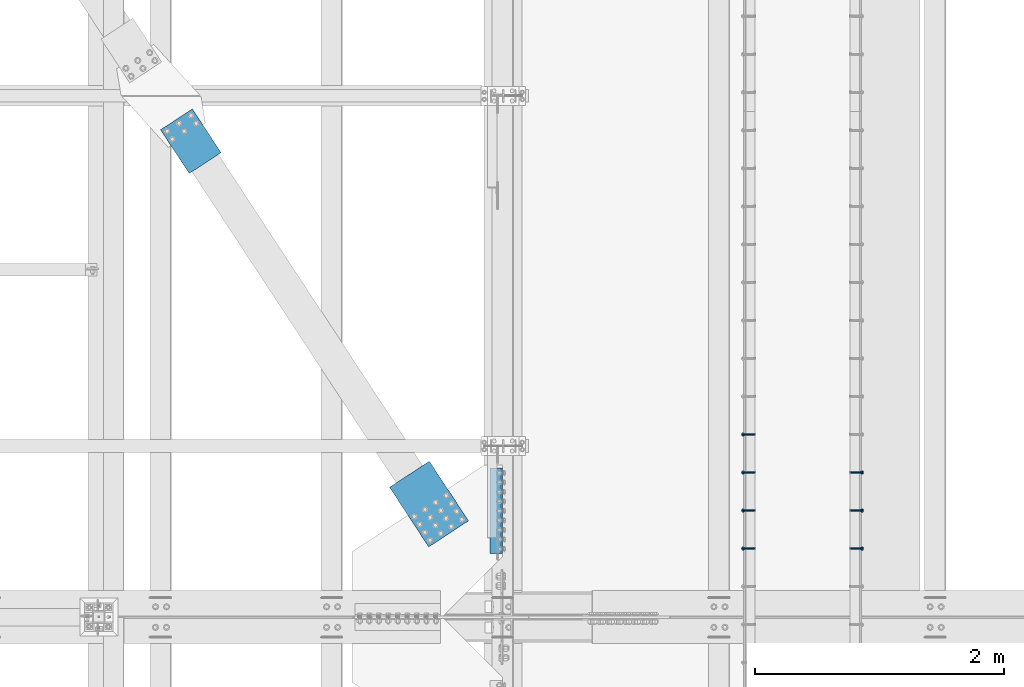
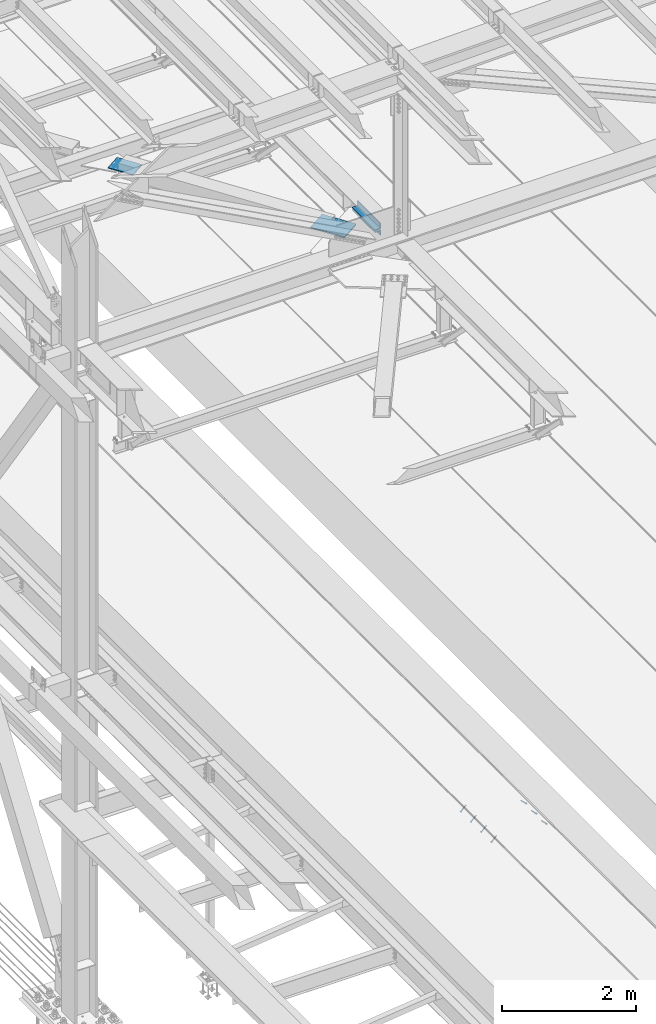
# One storey, part 2377 of 3843: 7 members, 4 beams, 4 elements without a shape of their own.
"""IFC2X3 building model written with IfcOpenShell, lengths in millimetres."""

import ifcopenshell
import ifcopenshell.guid

model = None  # the IFC model being written
_history = None  # IfcOwnerHistory: only IFC2X3 demands one
_inside = {}  # id of a spatial element -> (the spatial element, [elements in it])
_under = {}  # id of a project, library or spatial element -> (it, [spatial elements below it])
_declared = {}  # id of a project -> (the project, [libraries it declares])
_typed = {}  # id of a type object -> (the type object, [elements of that type])
_made_of = {}  # id of a material, layer set ... -> (it, [elements and type objects made of it])


def new_model(schema):
    """Start an empty IFC model of exactly this schema.

    Asked for "IFC4X3", IfcOpenShell would pick the latest addendum, in which some entities
    have other attributes; the version numbers below select the first issue.
    IFC2X3 requires an IfcOwnerHistory on every rooted entity: one is made here for all.
    """
    global model, _history
    if schema == "IFC4X3":
        model = ifcopenshell.file(schema_version=(4, 3, 0, 0))
    else:
        model = ifcopenshell.file(schema=schema)
    _inside.clear()
    _under.clear()
    _declared.clear()
    _typed.clear()
    _made_of.clear()
    _history = None
    if model.schema == "IFC2X3":
        org = make("IfcOrganization", Name="unknown")
        user = make(
            "IfcPersonAndOrganization",
            ThePerson=make("IfcPerson", FamilyName="unknown"),
            TheOrganization=org,
        )
        app = make(
            "IfcApplication",
            ApplicationDeveloper=org,
            Version="unknown",
            ApplicationFullName="unknown",
            ApplicationIdentifier="unknown",
        )
        _history = make(
            "IfcOwnerHistory",
            OwningUser=user,
            OwningApplication=app,
            ChangeAction="ADDED",
            CreationDate=0,
        )
    return model


def make(cls, **values):
    """One entity of the class cls with the attributes given. An attribute that is None is left unset."""
    return model.create_entity(
        cls, **{name: value for name, value in values.items() if value is not None}
    )


def rooted(cls, **values):
    """An entity with a GlobalId (a new one), such as an element, a storey or a relation."""
    return make(cls, GlobalId=ifcopenshell.guid.new(), OwnerHistory=_history, **values)


def si_unit(unit_type, name, prefix=None):
    """IfcSIUnit, for example si_unit("LENGTHUNIT", "METRE", prefix="MILLI")."""
    return make("IfcSIUnit", UnitType=unit_type, Prefix=prefix, Name=name)


def assignment(units):
    """IfcUnitAssignment: the units of a project."""
    return None if units is None else make("IfcUnitAssignment", Units=units)


def point(xyz):
    """IfcCartesianPoint."""
    return None if xyz is None else make("IfcCartesianPoint", Coordinates=xyz)


def direction(xyz):
    """IfcDirection."""
    return None if xyz is None else make("IfcDirection", DirectionRatios=xyz)


def frame(location, z_axis=None, x_axis=None):
    """IfcAxis2Placement3D, a coordinate frame: its origin and axes. An axis left out is left unset."""
    return make(
        "IfcAxis2Placement3D",
        Location=point(location),
        Axis=direction(z_axis),
        RefDirection=direction(x_axis),
    )


def origin_with_axes():
    """The frame at (0, 0, 0) with the z axis (0, 0, 1) and the x axis (1, 0, 0) written out."""
    return frame((0.0, 0.0, 0.0), z_axis=(0.0, 0.0, 1.0), x_axis=(1.0, 0.0, 0.0))


def place(relative_to, where):
    """IfcLocalPlacement: puts the frame where relative to a parent placement (None: the world)."""
    return make(
        "IfcLocalPlacement", PlacementRelTo=relative_to, RelativePlacement=where
    )


def context(
    kind, dimensions, precision=None, world=None, true_north=None, identifier=None
):
    """IfcGeometricRepresentationContext, for example the 3D "Model" context."""
    return make(
        "IfcGeometricRepresentationContext",
        ContextIdentifier=identifier,
        ContextType=kind,
        CoordinateSpaceDimension=dimensions,
        Precision=precision,
        WorldCoordinateSystem=world,
        TrueNorth=true_north,
    )


def subcontext(parent, identifier, kind, view, scale=None):
    """IfcGeometricRepresentationSubContext, for example "Body" below "Model"."""
    return make(
        "IfcGeometricRepresentationSubContext",
        ContextIdentifier=identifier,
        ContextType=kind,
        ParentContext=parent,
        TargetScale=scale,
        TargetView=view,
    )


def project(units=None, contexts=None):
    """IfcProject with its units and contexts."""
    return rooted(
        "IfcProject",
        Name="project",
        RepresentationContexts=contexts,
        UnitsInContext=assignment(units),
    )


def spatial(cls, under=None, at=None, **own):
    """A site, building, storey or space (cls), placed at a placement, below another one or the project."""
    s = rooted(cls, ObjectPlacement=at, **own)
    if under is not None:
        _under.setdefault(under.id(), (under, []))[1].append(s)
    return s


def faces_of(points, faces, orient=None, outer=None):
    """IfcFace entities. A face is a list of loops; a loop is a list of indices into points, from 0.

    orient and outer hold one flag for each loop. By default every Orientation is true, the
    first loop of a face is its IfcFaceOuterBound and the others are IfcFaceBound.
    """
    made = []
    for i, loops in enumerate(faces):
        bounds = []
        for j, loop in enumerate(loops):
            is_outer = j == 0 if outer is None else outer[i][j]
            bounds.append(
                make(
                    "IfcFaceOuterBound" if is_outer else "IfcFaceBound",
                    Bound=make("IfcPolyLoop", Polygon=[points[k] for k in loop]),
                    Orientation=True if orient is None else orient[i][j],
                )
            )
        made.append(make("IfcFace", Bounds=bounds))
    return made


def faceted_brep(points, faces, orient=None, outer=None, voids=None):
    """IfcFacetedBrep: a solid bounded by flat faces; with voids (closed shells), ...WithVoids."""
    shared = [point(p) for p in points]
    hull = make("IfcClosedShell", CfsFaces=faces_of(shared, faces, orient, outer))
    if voids is None:
        return make("IfcFacetedBrep", Outer=hull)
    return make(
        "IfcFacetedBrepWithVoids",
        Outer=hull,
        Voids=[
            make(cls, CfsFaces=faces_of(shared, fs, o, b)) for cls, fs, o, b in voids
        ],
    )


def shape(context_of_items, identifier, shape_type, items):
    """IfcShapeRepresentation: the items that make up one representation, for example the "Body"."""
    return make(
        "IfcShapeRepresentation",
        ContextOfItems=context_of_items,
        RepresentationIdentifier=identifier,
        RepresentationType=shape_type,
        Items=items,
    )


def material(Name=None, Category=None):
    """IfcMaterial."""
    return make("IfcMaterial", Name=Name, Category=Category)


def made_of(thing, what):
    """Note that an element or type object is made of a material, layer set ...; save() writes the relation."""
    if what is not None:
        _made_of.setdefault(what.id(), (what, []))[1].append(thing)
    return thing


def type_object(cls, material=None, **own):
    """A type object (cls), such as IfcWallType, which elements share."""
    return made_of(rooted(cls, **own), material)


def element(
    cls,
    number,
    at=None,
    inside=None,
    cuts=None,
    type_object=None,
    material=None,
    context=None,
    identifier="Body",
    shape_type=None,
    held_by="IfcProductDefinitionShape",
    body=None,
    shapes=None,
    **own,
):
    """One element of the class cls, such as IfcWall. Its Tag is "e" and its number.

    at: its placement. inside: the storey or other place that contains it. cuts: it is an
    opening in that element (IfcRelVoidsElement). A single representation is given by context,
    identifier, shape_type and body (its items); several are given by shapes. held_by: the class
    of the entity that holds the representations. save() writes the other relations.
    """
    e = rooted(cls, Tag="e%d" % number, ObjectPlacement=at, **own)
    if body is not None:
        shapes = [shape(context, identifier, shape_type, body)]
    if shapes is not None:
        e.Representation = make(held_by, Representations=shapes)
    if inside is not None:
        _inside.setdefault(inside.id(), (inside, []))[1].append(e)
    if cuts is not None:
        rooted(
            "IfcRelVoidsElement", RelatingBuildingElement=cuts, RelatedOpeningElement=e
        )
    if type_object is not None:
        _typed.setdefault(type_object.id(), (type_object, []))[1].append(e)
    return made_of(e, material)


def aggregate(whole, parts):
    """IfcRelAggregates: a whole, such as a stair, and the parts it consists of."""
    return rooted("IfcRelAggregates", RelatingObject=whole, RelatedObjects=parts)


def save(model, path):
    """Write the relations noted so far, then the file.

    IfcRelAggregates (storeys below a building ...), IfcRelContainedInSpatialStructure (elements
    in a storey), IfcRelDefinesByType, IfcRelAssociatesMaterial and IfcRelDeclares: one each for
    every whole, place, type object, material and project.
    """
    for whole, parts in _under.values():
        aggregate(whole, parts)
    for where, things in _inside.values():
        rooted(
            "IfcRelContainedInSpatialStructure",
            RelatedElements=things,
            RelatingStructure=where,
        )
    for kind, things in _typed.values():
        rooted("IfcRelDefinesByType", RelatedObjects=things, RelatingType=kind)
    for what, things in _made_of.values():
        rooted("IfcRelAssociatesMaterial", RelatedObjects=things, RelatingMaterial=what)
    for by, libraries in _declared.values():
        rooted("IfcRelDeclares", RelatingContext=by, RelatedDefinitions=libraries)
    model.write(path)


model = new_model("IFC2X3")

# Units and contexts
model_context = context("Model", 3, precision=1e-05, world=origin_with_axes())
body_context = subcontext(model_context, "Body", "Model", "MODEL_VIEW")
ifc_project = project(units=[si_unit("LENGTHUNIT", "METRE", prefix="MILLI"), si_unit("AREAUNIT", "SQUARE_METRE"), si_unit("VOLUMEUNIT", "CUBIC_METRE"), si_unit("MASSUNIT", "GRAM", prefix="KILO"), si_unit("TIMEUNIT", "SECOND"), si_unit("PLANEANGLEUNIT", "RADIAN"), si_unit("SOLIDANGLEUNIT", "STERADIAN"), si_unit("THERMODYNAMICTEMPERATUREUNIT", "DEGREE_CELSIUS"), si_unit("LUMINOUSINTENSITYUNIT", "LUMEN")], contexts=[model_context])

# Site, building, storey
site_placement = place(None, origin_with_axes())
site = spatial("IfcSite", under=ifc_project, at=site_placement, CompositionType="ELEMENT")
building_placement = place(site_placement, origin_with_axes())
building = spatial("IfcBuilding", under=site, at=building_placement, Name="Undefined", CompositionType="ELEMENT")
storey_placement = place(building_placement, origin_with_axes())
storey = spatial("IfcBuildingStorey", under=building, at=storey_placement, Name="Undefined", CompositionType="ELEMENT", Elevation=0.0)

# Assembly, members
assembly_1_placement = place(storey_placement, origin_with_axes())
assembly_1 = element("IfcElementAssembly", 1, at=assembly_1_placement, inside=storey, Name="EMBED_ANGLE", AssemblyPlace="NOTDEFINED", PredefinedType="RIGID_FRAME")
ifc_material_1 = material(Name="STEEL/A108")
member_type = type_object("IfcMemberType", PredefinedType="NOTDEFINED")
member_1_placement = place(assembly_1_placement, frame((44851.3834999999, 67821.175189209, 30456.1875), z_axis=(0.0, 1.0, 0.0), x_axis=(0.707106781186548, 0.0, -0.707106781186548)))
member_1 = element("IfcMember", 2, at=member_1_placement, type_object=member_type, material=ifc_material_1, Name="HEADED STUD ANCHOR", context=body_context, shape_type="Brep", body=[
    faceted_brep([(7.27595761418343e-12, -3.18000006675175, 5.5), (0.0, -5.49999999998363, 3.1800000667572), (118.110000000976, -5.49999999999091, 3.1800000667572), (118.110000000983, -3.18000006675175, 5.5), (0.0, -6.3499999046162, 0.0), (118.110000000968, -6.34999990461256, 0.0), (0.0, -5.49999999998363, -3.1800000667572), (118.110000000976, -5.49999999999091, -3.1800000667572), (7.27595761418343e-12, -3.18000006675175, -5.5), (118.110000000983, -3.18000006675175, -5.5), (7.27595761418343e-12, -1.81898940354586e-12, -6.34999990463257), (118.110000000968, -1.81898940354586e-12, -6.34999990463257), (0.0, 3.18000006675175, -5.5), (118.110000000968, 3.18000006674811, -5.5), (7.27595761418343e-12, 5.49999999998363, -3.1800000667572), (118.110000000983, 5.49999999998363, -3.1800000667572), (7.27595761418343e-12, 6.3499999046162, 0.0), (118.110000000976, 6.34999990461256, 0.0), (7.27595761418343e-12, 5.49999999998363, 3.1800000667572), (118.110000000983, 5.49999999998363, 3.1800000667572), (0.0, 3.18000006675175, 5.5), (118.110000000968, 3.18000006674811, 5.5), (7.27595761418343e-12, -1.81898940354586e-12, 6.34999990463257), (118.110000000968, -1.81898940354586e-12, 6.34999990463257), (120.650000000991, -10.9899997710909, 6.34999990463257), (120.650000000998, -6.34000015257152, 10.9899997711182), (120.650000000991, -12.6999998092379, 0.0), (120.650000000991, -10.9899997710909, -6.34999990463257), (120.650000000998, -6.34000015257152, -10.9899997711182), (120.650000000991, -1.81898940354586e-12, -12.6899995803833), (120.650000000991, 6.34000015257152, -10.9899997711182), (120.650000000998, 10.9899997710909, -6.34999990463257), (120.650000000991, 12.6999998092342, 0.0), (120.650000000998, 10.9899997710909, 6.34999990463257), (120.650000000991, 6.34000015257152, 10.9899997711182), (120.650000000991, -1.81898940354586e-12, 12.6899995803833), (127.000000001048, -10.9899997710945, 6.34999990463257), (127.000000001048, -6.34000015257152, 10.9899997711182), (127.000000001048, -12.6999998092342, 0.0), (127.000000001048, -10.9899997710945, -6.34999990463257), (127.000000001048, -6.34000015257152, -10.9899997711182), (127.000000001048, 1.81898940354586e-12, -12.6899995803833), (127.000000001048, 6.34000015256788, -10.9899997711182), (127.000000001048, 10.9899997710909, -6.34999990463257), (127.000000001048, 12.6999998092379, 0.0), (127.000000001048, 10.9899997710909, 6.34999990463257), (127.000000001048, 6.34000015256788, 10.9899997711182), (127.000000001048, 1.81898940354586e-12, 12.6899995803833)], [[[0, 1, 2, 3]], [[1, 4, 5, 2]], [[4, 6, 7, 5]], [[6, 8, 9, 7]], [[8, 10, 11, 9]], [[10, 12, 13, 11]], [[12, 14, 15, 13]], [[14, 16, 17, 15]], [[16, 18, 19, 17]], [[18, 20, 21, 19]], [[20, 22, 23, 21]], [[22, 0, 3, 23]], [[22, 20, 18, 16, 14, 12, 10, 8, 6, 4, 1, 0]], [[3, 2, 24, 25]], [[2, 5, 26, 24]], [[5, 7, 27, 26]], [[7, 9, 28, 27]], [[9, 11, 29, 28]], [[11, 13, 30, 29]], [[13, 15, 31, 30]], [[15, 17, 32, 31]], [[17, 19, 33, 32]], [[19, 21, 34, 33]], [[21, 23, 35, 34]], [[23, 3, 25, 35]], [[25, 24, 36, 37]], [[24, 26, 38, 36]], [[26, 27, 39, 38]], [[27, 28, 40, 39]], [[28, 29, 41, 40]], [[29, 30, 42, 41]], [[30, 31, 43, 42]], [[31, 32, 44, 43]], [[32, 33, 45, 44]], [[33, 34, 46, 45]], [[34, 35, 47, 46]], [[35, 25, 37, 47]], [[38, 39, 40, 41, 42, 43, 44, 45, 46, 47, 37, 36]]]),
])
member_2_placement = place(assembly_1_placement, frame((44851.3834999999, 68125.975189209, 30456.1875), z_axis=(0.0, 1.0, 0.0), x_axis=(0.707106781186548, 0.0, -0.707106781186548)))
member_2 = element("IfcMember", 3, at=member_2_placement, type_object=member_type, material=ifc_material_1, Name="HEADED STUD ANCHOR", context=body_context, shape_type="Brep", body=[
    faceted_brep([(7.27595761418343e-12, -3.18000006675175, 5.5), (0.0, -5.49999999998363, 3.1800000667572), (118.110000000976, -5.49999999999091, 3.1800000667572), (118.110000000983, -3.18000006675175, 5.5), (0.0, -6.3499999046162, 0.0), (118.110000000968, -6.34999990461256, 0.0), (0.0, -5.49999999998363, -3.1800000667572), (118.110000000976, -5.49999999999091, -3.1800000667572), (7.27595761418343e-12, -3.18000006675175, -5.5), (118.110000000983, -3.18000006675175, -5.5), (7.27595761418343e-12, -1.81898940354586e-12, -6.34999990463257), (118.110000000968, -1.81898940354586e-12, -6.34999990463257), (0.0, 3.18000006675175, -5.5), (118.110000000968, 3.18000006674811, -5.5), (7.27595761418343e-12, 5.49999999998363, -3.1800000667572), (118.110000000983, 5.49999999998363, -3.1800000667572), (7.27595761418343e-12, 6.3499999046162, 0.0), (118.110000000976, 6.34999990461256, 0.0), (7.27595761418343e-12, 5.49999999998363, 3.1800000667572), (118.110000000983, 5.49999999998363, 3.1800000667572), (0.0, 3.18000006675175, 5.5), (118.110000000968, 3.18000006674811, 5.5), (7.27595761418343e-12, -1.81898940354586e-12, 6.34999990463257), (118.110000000968, -1.81898940354586e-12, 6.34999990463257), (120.650000000991, -10.9899997710909, 6.34999990463257), (120.650000000998, -6.34000015257152, 10.9899997711182), (120.650000000991, -12.6999998092379, 0.0), (120.650000000991, -10.9899997710909, -6.34999990463257), (120.650000000998, -6.34000015257152, -10.9899997711182), (120.650000000991, -1.81898940354586e-12, -12.6899995803833), (120.650000000991, 6.34000015257152, -10.9899997711182), (120.650000000998, 10.9899997710909, -6.34999990463257), (120.650000000991, 12.6999998092342, 0.0), (120.650000000998, 10.9899997710909, 6.34999990463257), (120.650000000991, 6.34000015257152, 10.9899997711182), (120.650000000991, -1.81898940354586e-12, 12.6899995803833), (127.000000001048, -10.9899997710945, 6.34999990463257), (127.000000001048, -6.34000015257152, 10.9899997711182), (127.000000001048, -12.6999998092342, 0.0), (127.000000001048, -10.9899997710945, -6.34999990463257), (127.000000001048, -6.34000015257152, -10.9899997711182), (127.000000001048, 1.81898940354586e-12, -12.6899995803833), (127.000000001048, 6.34000015256788, -10.9899997711182), (127.000000001048, 10.9899997710909, -6.34999990463257), (127.000000001048, 12.6999998092379, 0.0), (127.000000001048, 10.9899997710909, 6.34999990463257), (127.000000001048, 6.34000015256788, 10.9899997711182), (127.000000001048, 1.81898940354586e-12, 12.6899995803833)], [[[0, 1, 2, 3]], [[1, 4, 5, 2]], [[4, 6, 7, 5]], [[6, 8, 9, 7]], [[8, 10, 11, 9]], [[10, 12, 13, 11]], [[12, 14, 15, 13]], [[14, 16, 17, 15]], [[16, 18, 19, 17]], [[18, 20, 21, 19]], [[20, 22, 23, 21]], [[22, 0, 3, 23]], [[22, 20, 18, 16, 14, 12, 10, 8, 6, 4, 1, 0]], [[3, 2, 24, 25]], [[2, 5, 26, 24]], [[5, 7, 27, 26]], [[7, 9, 28, 27]], [[9, 11, 29, 28]], [[11, 13, 30, 29]], [[13, 15, 31, 30]], [[15, 17, 32, 31]], [[17, 19, 33, 32]], [[19, 21, 34, 33]], [[21, 23, 35, 34]], [[23, 3, 25, 35]], [[25, 24, 36, 37]], [[24, 26, 38, 36]], [[26, 27, 39, 38]], [[27, 28, 40, 39]], [[28, 29, 41, 40]], [[29, 30, 42, 41]], [[30, 31, 43, 42]], [[31, 32, 44, 43]], [[32, 33, 45, 44]], [[33, 34, 46, 45]], [[34, 35, 47, 46]], [[35, 25, 37, 47]], [[38, 39, 40, 41, 42, 43, 44, 45, 46, 47, 37, 36]]]),
])
member_3_placement = place(assembly_1_placement, frame((44851.3834999999, 68430.775189209, 30456.1875), z_axis=(0.0, 1.0, 0.0), x_axis=(0.707106781186548, 0.0, -0.707106781186548)))
member_3 = element("IfcMember", 4, at=member_3_placement, type_object=member_type, material=ifc_material_1, Name="HEADED STUD ANCHOR", context=body_context, shape_type="Brep", body=[
    faceted_brep([(7.27595761418343e-12, -3.18000006675175, 5.5), (0.0, -5.49999999998363, 3.1800000667572), (118.110000000976, -5.49999999999091, 3.1800000667572), (118.110000000983, -3.18000006675175, 5.5), (0.0, -6.3499999046162, 0.0), (118.110000000968, -6.34999990461256, 0.0), (0.0, -5.49999999998363, -3.1800000667572), (118.110000000976, -5.49999999999091, -3.1800000667572), (7.27595761418343e-12, -3.18000006675175, -5.5), (118.110000000983, -3.18000006675175, -5.5), (7.27595761418343e-12, -1.81898940354586e-12, -6.34999990463257), (118.110000000968, -1.81898940354586e-12, -6.34999990463257), (0.0, 3.18000006675175, -5.5), (118.110000000968, 3.18000006674811, -5.5), (7.27595761418343e-12, 5.49999999998363, -3.1800000667572), (118.110000000983, 5.49999999998363, -3.1800000667572), (7.27595761418343e-12, 6.3499999046162, 0.0), (118.110000000976, 6.34999990461256, 0.0), (7.27595761418343e-12, 5.49999999998363, 3.1800000667572), (118.110000000983, 5.49999999998363, 3.1800000667572), (0.0, 3.18000006675175, 5.5), (118.110000000968, 3.18000006674811, 5.5), (7.27595761418343e-12, -1.81898940354586e-12, 6.34999990463257), (118.110000000968, -1.81898940354586e-12, 6.34999990463257), (120.650000000991, -10.9899997710909, 6.34999990463257), (120.650000000998, -6.34000015257152, 10.9899997711182), (120.650000000991, -12.6999998092379, 0.0), (120.650000000991, -10.9899997710909, -6.34999990463257), (120.650000000998, -6.34000015257152, -10.9899997711182), (120.650000000991, -1.81898940354586e-12, -12.6899995803833), (120.650000000991, 6.34000015257152, -10.9899997711182), (120.650000000998, 10.9899997710909, -6.34999990463257), (120.650000000991, 12.6999998092342, 0.0), (120.650000000998, 10.9899997710909, 6.34999990463257), (120.650000000991, 6.34000015257152, 10.9899997711182), (120.650000000991, -1.81898940354586e-12, 12.6899995803833), (127.000000001048, -10.9899997710945, 6.34999990463257), (127.000000001048, -6.34000015257152, 10.9899997711182), (127.000000001048, -12.6999998092342, 0.0), (127.000000001048, -10.9899997710945, -6.34999990463257), (127.000000001048, -6.34000015257152, -10.9899997711182), (127.000000001048, 1.81898940354586e-12, -12.6899995803833), (127.000000001048, 6.34000015256788, -10.9899997711182), (127.000000001048, 10.9899997710909, -6.34999990463257), (127.000000001048, 12.6999998092379, 0.0), (127.000000001048, 10.9899997710909, 6.34999990463257), (127.000000001048, 6.34000015256788, 10.9899997711182), (127.000000001048, 1.81898940354586e-12, 12.6899995803833)], [[[0, 1, 2, 3]], [[1, 4, 5, 2]], [[4, 6, 7, 5]], [[6, 8, 9, 7]], [[8, 10, 11, 9]], [[10, 12, 13, 11]], [[12, 14, 15, 13]], [[14, 16, 17, 15]], [[16, 18, 19, 17]], [[18, 20, 21, 19]], [[20, 22, 23, 21]], [[22, 0, 3, 23]], [[22, 20, 18, 16, 14, 12, 10, 8, 6, 4, 1, 0]], [[3, 2, 24, 25]], [[2, 5, 26, 24]], [[5, 7, 27, 26]], [[7, 9, 28, 27]], [[9, 11, 29, 28]], [[11, 13, 30, 29]], [[13, 15, 31, 30]], [[15, 17, 32, 31]], [[17, 19, 33, 32]], [[19, 21, 34, 33]], [[21, 23, 35, 34]], [[23, 3, 25, 35]], [[25, 24, 36, 37]], [[24, 26, 38, 36]], [[26, 27, 39, 38]], [[27, 28, 40, 39]], [[28, 29, 41, 40]], [[29, 30, 42, 41]], [[30, 31, 43, 42]], [[31, 32, 44, 43]], [[32, 33, 45, 44]], [[33, 34, 46, 45]], [[34, 35, 47, 46]], [[35, 25, 37, 47]], [[38, 39, 40, 41, 42, 43, 44, 45, 46, 47, 37, 36]]]),
])
aggregate(assembly_1, [member_1, member_2, member_3])

assembly_2_placement = place(storey_placement, origin_with_axes())
assembly_2 = element("IfcElementAssembly", 5, at=assembly_2_placement, inside=storey, Name="EMBED_ANGLE", AssemblyPlace="NOTDEFINED", PredefinedType="RIGID_FRAME")
member_4_placement = place(assembly_2_placement, frame((44073.5085000003, 67821.175189209, 30456.1874999998), z_axis=(0.0, -1.0, 0.0), x_axis=(-0.707106781186548, 0.0, -0.707106781186548)))
member_4 = element("IfcMember", 6, at=member_4_placement, type_object=member_type, material=ifc_material_1, Name="HEADED STUD ANCHOR", context=body_context, shape_type="Brep", body=[
    faceted_brep([(7.27595761418343e-12, -3.18000006675175, 5.5), (0.0, -5.49999999998363, 3.1800000667572), (118.110000000976, -5.49999999999091, 3.1800000667572), (118.110000000983, -3.18000006675175, 5.5), (0.0, -6.3499999046162, 0.0), (118.110000000968, -6.34999990461256, 0.0), (0.0, -5.49999999998363, -3.1800000667572), (118.110000000976, -5.49999999999091, -3.1800000667572), (7.27595761418343e-12, -3.18000006675175, -5.5), (118.110000000983, -3.18000006675175, -5.5), (7.27595761418343e-12, -1.81898940354586e-12, -6.34999990463257), (118.110000000968, -1.81898940354586e-12, -6.34999990463257), (0.0, 3.18000006675175, -5.5), (118.110000000968, 3.18000006674811, -5.5), (7.27595761418343e-12, 5.49999999998363, -3.1800000667572), (118.110000000983, 5.49999999998363, -3.1800000667572), (7.27595761418343e-12, 6.3499999046162, 0.0), (118.110000000976, 6.34999990461256, 0.0), (7.27595761418343e-12, 5.49999999998363, 3.1800000667572), (118.110000000983, 5.49999999998363, 3.1800000667572), (0.0, 3.18000006675175, 5.5), (118.110000000968, 3.18000006674811, 5.5), (7.27595761418343e-12, -1.81898940354586e-12, 6.34999990463257), (118.110000000968, -1.81898940354586e-12, 6.34999990463257), (120.650000000991, -10.9899997710909, 6.34999990463257), (120.650000000998, -6.34000015257152, 10.9899997711182), (120.650000000991, -12.6999998092379, 0.0), (120.650000000991, -10.9899997710909, -6.34999990463257), (120.650000000998, -6.34000015257152, -10.9899997711182), (120.650000000991, -1.81898940354586e-12, -12.6899995803833), (120.650000000991, 6.34000015257152, -10.9899997711182), (120.650000000998, 10.9899997710909, -6.34999990463257), (120.650000000991, 12.6999998092342, 0.0), (120.650000000998, 10.9899997710909, 6.34999990463257), (120.650000000991, 6.34000015257152, 10.9899997711182), (120.650000000991, -1.81898940354586e-12, 12.6899995803833), (127.000000001048, -10.9899997710945, 6.34999990463257), (127.000000001048, -6.34000015257152, 10.9899997711182), (127.000000001048, -12.6999998092342, 0.0), (127.000000001048, -10.9899997710945, -6.34999990463257), (127.000000001048, -6.34000015257152, -10.9899997711182), (127.000000001048, 1.81898940354586e-12, -12.6899995803833), (127.000000001048, 6.34000015256788, -10.9899997711182), (127.000000001048, 10.9899997710909, -6.34999990463257), (127.000000001048, 12.6999998092379, 0.0), (127.000000001048, 10.9899997710909, 6.34999990463257), (127.000000001048, 6.34000015256788, 10.9899997711182), (127.000000001048, 1.81898940354586e-12, 12.6899995803833)], [[[0, 1, 2, 3]], [[1, 4, 5, 2]], [[4, 6, 7, 5]], [[6, 8, 9, 7]], [[8, 10, 11, 9]], [[10, 12, 13, 11]], [[12, 14, 15, 13]], [[14, 16, 17, 15]], [[16, 18, 19, 17]], [[18, 20, 21, 19]], [[20, 22, 23, 21]], [[22, 0, 3, 23]], [[22, 20, 18, 16, 14, 12, 10, 8, 6, 4, 1, 0]], [[3, 2, 24, 25]], [[2, 5, 26, 24]], [[5, 7, 27, 26]], [[7, 9, 28, 27]], [[9, 11, 29, 28]], [[11, 13, 30, 29]], [[13, 15, 31, 30]], [[15, 17, 32, 31]], [[17, 19, 33, 32]], [[19, 21, 34, 33]], [[21, 23, 35, 34]], [[23, 3, 25, 35]], [[25, 24, 36, 37]], [[24, 26, 38, 36]], [[26, 27, 39, 38]], [[27, 28, 40, 39]], [[28, 29, 41, 40]], [[29, 30, 42, 41]], [[30, 31, 43, 42]], [[31, 32, 44, 43]], [[32, 33, 45, 44]], [[33, 34, 46, 45]], [[34, 35, 47, 46]], [[35, 25, 37, 47]], [[38, 39, 40, 41, 42, 43, 44, 45, 46, 47, 37, 36]]]),
])
member_5_placement = place(assembly_2_placement, frame((44073.5085000003, 68125.975189209, 30456.1874999998), z_axis=(0.0, -1.0, 0.0), x_axis=(-0.707106781186548, 0.0, -0.707106781186548)))
member_5 = element("IfcMember", 7, at=member_5_placement, type_object=member_type, material=ifc_material_1, Name="HEADED STUD ANCHOR", context=body_context, shape_type="Brep", body=[
    faceted_brep([(7.27595761418343e-12, -3.18000006675175, 5.5), (0.0, -5.49999999998363, 3.1800000667572), (118.110000000976, -5.49999999999091, 3.1800000667572), (118.110000000983, -3.18000006675175, 5.5), (0.0, -6.3499999046162, 0.0), (118.110000000968, -6.34999990461256, 0.0), (0.0, -5.49999999998363, -3.1800000667572), (118.110000000976, -5.49999999999091, -3.1800000667572), (7.27595761418343e-12, -3.18000006675175, -5.5), (118.110000000983, -3.18000006675175, -5.5), (7.27595761418343e-12, -1.81898940354586e-12, -6.34999990463257), (118.110000000968, -1.81898940354586e-12, -6.34999990463257), (0.0, 3.18000006675175, -5.5), (118.110000000968, 3.18000006674811, -5.5), (7.27595761418343e-12, 5.49999999998363, -3.1800000667572), (118.110000000983, 5.49999999998363, -3.1800000667572), (7.27595761418343e-12, 6.3499999046162, 0.0), (118.110000000976, 6.34999990461256, 0.0), (7.27595761418343e-12, 5.49999999998363, 3.1800000667572), (118.110000000983, 5.49999999998363, 3.1800000667572), (0.0, 3.18000006675175, 5.5), (118.110000000968, 3.18000006674811, 5.5), (7.27595761418343e-12, -1.81898940354586e-12, 6.34999990463257), (118.110000000968, -1.81898940354586e-12, 6.34999990463257), (120.650000000991, -10.9899997710909, 6.34999990463257), (120.650000000998, -6.34000015257152, 10.9899997711182), (120.650000000991, -12.6999998092379, 0.0), (120.650000000991, -10.9899997710909, -6.34999990463257), (120.650000000998, -6.34000015257152, -10.9899997711182), (120.650000000991, -1.81898940354586e-12, -12.6899995803833), (120.650000000991, 6.34000015257152, -10.9899997711182), (120.650000000998, 10.9899997710909, -6.34999990463257), (120.650000000991, 12.6999998092342, 0.0), (120.650000000998, 10.9899997710909, 6.34999990463257), (120.650000000991, 6.34000015257152, 10.9899997711182), (120.650000000991, -1.81898940354586e-12, 12.6899995803833), (127.000000001048, -10.9899997710945, 6.34999990463257), (127.000000001048, -6.34000015257152, 10.9899997711182), (127.000000001048, -12.6999998092342, 0.0), (127.000000001048, -10.9899997710945, -6.34999990463257), (127.000000001048, -6.34000015257152, -10.9899997711182), (127.000000001048, 1.81898940354586e-12, -12.6899995803833), (127.000000001048, 6.34000015256788, -10.9899997711182), (127.000000001048, 10.9899997710909, -6.34999990463257), (127.000000001048, 12.6999998092379, 0.0), (127.000000001048, 10.9899997710909, 6.34999990463257), (127.000000001048, 6.34000015256788, 10.9899997711182), (127.000000001048, 1.81898940354586e-12, 12.6899995803833)], [[[0, 1, 2, 3]], [[1, 4, 5, 2]], [[4, 6, 7, 5]], [[6, 8, 9, 7]], [[8, 10, 11, 9]], [[10, 12, 13, 11]], [[12, 14, 15, 13]], [[14, 16, 17, 15]], [[16, 18, 19, 17]], [[18, 20, 21, 19]], [[20, 22, 23, 21]], [[22, 0, 3, 23]], [[22, 20, 18, 16, 14, 12, 10, 8, 6, 4, 1, 0]], [[3, 2, 24, 25]], [[2, 5, 26, 24]], [[5, 7, 27, 26]], [[7, 9, 28, 27]], [[9, 11, 29, 28]], [[11, 13, 30, 29]], [[13, 15, 31, 30]], [[15, 17, 32, 31]], [[17, 19, 33, 32]], [[19, 21, 34, 33]], [[21, 23, 35, 34]], [[23, 3, 25, 35]], [[25, 24, 36, 37]], [[24, 26, 38, 36]], [[26, 27, 39, 38]], [[27, 28, 40, 39]], [[28, 29, 41, 40]], [[29, 30, 42, 41]], [[30, 31, 43, 42]], [[31, 32, 44, 43]], [[32, 33, 45, 44]], [[33, 34, 46, 45]], [[34, 35, 47, 46]], [[35, 25, 37, 47]], [[38, 39, 40, 41, 42, 43, 44, 45, 46, 47, 37, 36]]]),
])
member_6_placement = place(assembly_2_placement, frame((44073.5085000003, 68430.775189209, 30456.1874999998), z_axis=(0.0, -1.0, 0.0), x_axis=(-0.707106781186548, 0.0, -0.707106781186548)))
member_6 = element("IfcMember", 8, at=member_6_placement, type_object=member_type, material=ifc_material_1, Name="HEADED STUD ANCHOR", context=body_context, shape_type="Brep", body=[
    faceted_brep([(7.27595761418343e-12, -3.18000006675175, 5.5), (0.0, -5.49999999998363, 3.1800000667572), (118.110000000976, -5.49999999999091, 3.1800000667572), (118.110000000983, -3.18000006675175, 5.5), (0.0, -6.3499999046162, 0.0), (118.110000000968, -6.34999990461256, 0.0), (0.0, -5.49999999998363, -3.1800000667572), (118.110000000976, -5.49999999999091, -3.1800000667572), (7.27595761418343e-12, -3.18000006675175, -5.5), (118.110000000983, -3.18000006675175, -5.5), (7.27595761418343e-12, -1.81898940354586e-12, -6.34999990463257), (118.110000000968, -1.81898940354586e-12, -6.34999990463257), (0.0, 3.18000006675175, -5.5), (118.110000000968, 3.18000006674811, -5.5), (7.27595761418343e-12, 5.49999999998363, -3.1800000667572), (118.110000000983, 5.49999999998363, -3.1800000667572), (7.27595761418343e-12, 6.3499999046162, 0.0), (118.110000000976, 6.34999990461256, 0.0), (7.27595761418343e-12, 5.49999999998363, 3.1800000667572), (118.110000000983, 5.49999999998363, 3.1800000667572), (0.0, 3.18000006675175, 5.5), (118.110000000968, 3.18000006674811, 5.5), (7.27595761418343e-12, -1.81898940354586e-12, 6.34999990463257), (118.110000000968, -1.81898940354586e-12, 6.34999990463257), (120.650000000991, -10.9899997710909, 6.34999990463257), (120.650000000998, -6.34000015257152, 10.9899997711182), (120.650000000991, -12.6999998092379, 0.0), (120.650000000991, -10.9899997710909, -6.34999990463257), (120.650000000998, -6.34000015257152, -10.9899997711182), (120.650000000991, -1.81898940354586e-12, -12.6899995803833), (120.650000000991, 6.34000015257152, -10.9899997711182), (120.650000000998, 10.9899997710909, -6.34999990463257), (120.650000000991, 12.6999998092342, 0.0), (120.650000000998, 10.9899997710909, 6.34999990463257), (120.650000000991, 6.34000015257152, 10.9899997711182), (120.650000000991, -1.81898940354586e-12, 12.6899995803833), (127.000000001048, -10.9899997710945, 6.34999990463257), (127.000000001048, -6.34000015257152, 10.9899997711182), (127.000000001048, -12.6999998092342, 0.0), (127.000000001048, -10.9899997710945, -6.34999990463257), (127.000000001048, -6.34000015257152, -10.9899997711182), (127.000000001048, 1.81898940354586e-12, -12.6899995803833), (127.000000001048, 6.34000015256788, -10.9899997711182), (127.000000001048, 10.9899997710909, -6.34999990463257), (127.000000001048, 12.6999998092379, 0.0), (127.000000001048, 10.9899997710909, 6.34999990463257), (127.000000001048, 6.34000015256788, 10.9899997711182), (127.000000001048, 1.81898940354586e-12, 12.6899995803833)], [[[0, 1, 2, 3]], [[1, 4, 5, 2]], [[4, 6, 7, 5]], [[6, 8, 9, 7]], [[8, 10, 11, 9]], [[10, 12, 13, 11]], [[12, 14, 15, 13]], [[14, 16, 17, 15]], [[16, 18, 19, 17]], [[18, 20, 21, 19]], [[20, 22, 23, 21]], [[22, 0, 3, 23]], [[22, 20, 18, 16, 14, 12, 10, 8, 6, 4, 1, 0]], [[3, 2, 24, 25]], [[2, 5, 26, 24]], [[5, 7, 27, 26]], [[7, 9, 28, 27]], [[9, 11, 29, 28]], [[11, 13, 30, 29]], [[13, 15, 31, 30]], [[15, 17, 32, 31]], [[17, 19, 33, 32]], [[19, 21, 34, 33]], [[21, 23, 35, 34]], [[23, 3, 25, 35]], [[25, 24, 36, 37]], [[24, 26, 38, 36]], [[26, 27, 39, 38]], [[27, 28, 40, 39]], [[28, 29, 41, 40]], [[29, 30, 42, 41]], [[30, 31, 43, 42]], [[31, 32, 44, 43]], [[32, 33, 45, 44]], [[33, 34, 46, 45]], [[34, 35, 47, 46]], [[35, 25, 37, 47]], [[38, 39, 40, 41, 42, 43, 44, 45, 46, 47, 37, 36]]]),
])
member_7_placement = place(assembly_2_placement, frame((44073.5085000003, 68735.575189209, 30456.1874999998), z_axis=(0.0, -1.0, 0.0), x_axis=(-0.707106781186548, 0.0, -0.707106781186548)))
member_7 = element("IfcMember", 9, at=member_7_placement, type_object=member_type, material=ifc_material_1, Name="HEADED STUD ANCHOR", context=body_context, shape_type="Brep", body=[
    faceted_brep([(7.27595761418343e-12, -3.18000006675175, 5.5), (0.0, -5.49999999998363, 3.1800000667572), (118.110000000976, -5.49999999999091, 3.1800000667572), (118.110000000983, -3.18000006675175, 5.5), (0.0, -6.3499999046162, 0.0), (118.110000000968, -6.34999990461256, 0.0), (0.0, -5.49999999998363, -3.1800000667572), (118.110000000976, -5.49999999999091, -3.1800000667572), (7.27595761418343e-12, -3.18000006675175, -5.5), (118.110000000983, -3.18000006675175, -5.5), (7.27595761418343e-12, -1.81898940354586e-12, -6.34999990463257), (118.110000000968, -1.81898940354586e-12, -6.34999990463257), (0.0, 3.18000006675175, -5.5), (118.110000000968, 3.18000006674811, -5.5), (7.27595761418343e-12, 5.49999999998363, -3.1800000667572), (118.110000000983, 5.49999999998363, -3.1800000667572), (7.27595761418343e-12, 6.3499999046162, 0.0), (118.110000000976, 6.34999990461256, 0.0), (7.27595761418343e-12, 5.49999999998363, 3.1800000667572), (118.110000000983, 5.49999999998363, 3.1800000667572), (0.0, 3.18000006675175, 5.5), (118.110000000968, 3.18000006674811, 5.5), (7.27595761418343e-12, -1.81898940354586e-12, 6.34999990463257), (118.110000000968, -1.81898940354586e-12, 6.34999990463257), (120.650000000991, -10.9899997710909, 6.34999990463257), (120.650000000998, -6.34000015257152, 10.9899997711182), (120.650000000991, -12.6999998092379, 0.0), (120.650000000991, -10.9899997710909, -6.34999990463257), (120.650000000998, -6.34000015257152, -10.9899997711182), (120.650000000991, -1.81898940354586e-12, -12.6899995803833), (120.650000000991, 6.34000015257152, -10.9899997711182), (120.650000000998, 10.9899997710909, -6.34999990463257), (120.650000000991, 12.6999998092342, 0.0), (120.650000000998, 10.9899997710909, 6.34999990463257), (120.650000000991, 6.34000015257152, 10.9899997711182), (120.650000000991, -1.81898940354586e-12, 12.6899995803833), (127.000000001048, -10.9899997710945, 6.34999990463257), (127.000000001048, -6.34000015257152, 10.9899997711182), (127.000000001048, -12.6999998092342, 0.0), (127.000000001048, -10.9899997710945, -6.34999990463257), (127.000000001048, -6.34000015257152, -10.9899997711182), (127.000000001048, 1.81898940354586e-12, -12.6899995803833), (127.000000001048, 6.34000015256788, -10.9899997711182), (127.000000001048, 10.9899997710909, -6.34999990463257), (127.000000001048, 12.6999998092379, 0.0), (127.000000001048, 10.9899997710909, 6.34999990463257), (127.000000001048, 6.34000015256788, 10.9899997711182), (127.000000001048, 1.81898940354586e-12, 12.6899995803833)], [[[0, 1, 2, 3]], [[1, 4, 5, 2]], [[4, 6, 7, 5]], [[6, 8, 9, 7]], [[8, 10, 11, 9]], [[10, 12, 13, 11]], [[12, 14, 15, 13]], [[14, 16, 17, 15]], [[16, 18, 19, 17]], [[18, 20, 21, 19]], [[20, 22, 23, 21]], [[22, 0, 3, 23]], [[22, 20, 18, 16, 14, 12, 10, 8, 6, 4, 1, 0]], [[3, 2, 24, 25]], [[2, 5, 26, 24]], [[5, 7, 27, 26]], [[7, 9, 28, 27]], [[9, 11, 29, 28]], [[11, 13, 30, 29]], [[13, 15, 31, 30]], [[15, 17, 32, 31]], [[17, 19, 33, 32]], [[19, 21, 34, 33]], [[21, 23, 35, 34]], [[23, 3, 25, 35]], [[25, 24, 36, 37]], [[24, 26, 38, 36]], [[26, 27, 39, 38]], [[27, 28, 40, 39]], [[28, 29, 41, 40]], [[29, 30, 42, 41]], [[30, 31, 43, 42]], [[31, 32, 44, 43]], [[32, 33, 45, 44]], [[33, 34, 46, 45]], [[34, 35, 47, 46]], [[35, 25, 37, 47]], [[38, 39, 40, 41, 42, 43, 44, 45, 46, 47, 37, 36]]]),
])
aggregate(assembly_2, [member_4, member_5, member_6, member_7])

# Assembly, beam
assembly_3_placement = place(storey_placement, origin_with_axes())
assembly_3 = element("IfcElementAssembly", 10, at=assembly_3_placement, inside=storey, AssemblyPlace="NOTDEFINED", PredefinedType="RIGID_FRAME")
ifc_material_2 = material(Name="STEEL/A572-50")
beam_type_1 = type_object("IfcBeamType", PredefinedType="NOTDEFINED")
beam_1_placement = place(assembly_3_placement, frame((39442.9014380659, 71261.7843854556, 42252.9), z_axis=(-0.835938629021657, -0.548822930014219, 0.0), x_axis=(0.548822930014218, -0.835938629021658, 0.0)))
beam_1 = element("IfcBeam", 11, at=beam_1_placement, type_object=beam_type_1, material=ifc_material_2, Name="PLATE", context=body_context, shape_type="Brep", body=[
    faceted_brep([(-1.0550138540566e-10, 6.34999999999854, -152.400000000664), (1.0550138540566e-10, 6.34999999999854, 152.400000000656), (419.100000001017, 6.34999999999854, 152.400000000365), (419.100000000799, 6.34999999999854, -152.400000000969), (1.0550138540566e-10, -6.34999999999854, 152.400000000656), (419.100000001017, -6.34999999999854, 152.400000000365), (-1.0550138540566e-10, -6.34999999999854, -152.400000000664), (419.100000000799, -6.34999999999854, -152.400000000969)], [[[0, 1, 2, 3]], [[1, 4, 5, 2]], [[4, 6, 7, 5]], [[6, 0, 3, 7]], [[5, 7, 3, 2]], [[6, 4, 1, 0]]]),
])

# Assembly, beams
assembly_4_placement = place(storey_placement, origin_with_axes())
assembly_4 = element("IfcElementAssembly", 12, at=assembly_4_placement, inside=storey, Name="PLATE", AssemblyPlace="NOTDEFINED", PredefinedType="RIGID_FRAME")
beam_type_2 = type_object("IfcBeamType", Name="L4X4X1/2", PredefinedType="NOTDEFINED")
beam_2_placement = place(assembly_4_placement, frame((42006.8375, 67779.8999999999, 42297.3500007629), z_axis=(-1.0, 0.0, 0.0), x_axis=(0.0, 1.0, 0.0)))
beam_2 = element("IfcBeam", 13, at=beam_2_placement, type_object=beam_type_2, material=ifc_material_2, Name="ANGLE", ObjectType="L4X4X1/2", context=body_context, shape_type="Brep", body=[
    faceted_brep([(0.0, 50.8000000000029, -50.8000000000029), (0.0, 50.8000000000029, 50.8000000000029), (685.800000000003, 50.8000000000029, 50.8000000000029), (685.800000000003, 50.8000000000029, -50.8000000000029), (0.0, 38.0999999999985, 50.8000000000029), (685.800000000003, 38.0999999999985, 50.8000000000029), (0.0, 38.0999999999985, -38.0999999999985), (685.800000000003, 38.0999999999985, -38.1000000000058), (0.0, -50.8000000000029, -38.1000000000058), (685.800000000003, -50.8000000000029, -38.1000000000058), (0.0, -50.8000000000029, -50.8000000000029), (685.800000000003, -50.8000000000029, -50.8000000000029)], [[[0, 1, 2, 3]], [[1, 4, 5, 2]], [[4, 6, 7, 5]], [[6, 8, 9, 7]], [[8, 10, 11, 9]], [[10, 0, 3, 11]], [[5, 7, 9, 11, 3, 2]], [[10, 8, 6, 4, 1, 0]]]),
])
beam_type_3 = type_object("IfcBeamType", Name="L4X3-1/2X1/2", PredefinedType="NOTDEFINED")
beam_3_placement = place(assembly_4_placement, frame((42006.8375, 68465.6999999999, 42173.5249984741), z_axis=(-1.0, 0.0, 0.0), x_axis=(0.0, -1.0, 0.0)))
beam_3 = element("IfcBeam", 14, at=beam_3_placement, type_object=beam_type_3, material=ifc_material_2, Name="ANGLE", ObjectType="L4X3-1/2X1/2", context=body_context, shape_type="Brep", body=[
    faceted_brep([(0.0, 44.4499999999971, -50.8000000000029), (0.0, 44.4499999999971, 50.8000000000029), (685.800000000003, 44.4499999999971, 50.8000000000029), (685.800000000003, 44.4499999999971, -50.8000000000029), (0.0, 31.75, 50.8000000000029), (685.800000000003, 31.75, 50.8000000000029), (0.0, 31.7500000838336, -38.0999999999985), (685.800000000003, 31.75, -38.0999999999985), (4.36557456851006e-11, -44.4500000000226, -38.0999999999985), (685.800000000003, -44.4499999999971, -38.0999999999985), (0.0, -44.4499999999971, -50.8000000000029), (685.800000000003, -44.4499999999971, -50.8000000000029)], [[[0, 1, 2, 3]], [[1, 4, 5, 2]], [[4, 6, 7, 5]], [[6, 8, 9, 7]], [[8, 10, 11, 9]], [[10, 0, 3, 11]], [[5, 7, 9, 11, 3, 2]], [[10, 8, 6, 4, 1, 0]]]),
])
aggregate(assembly_4, [beam_3, beam_2])

# Beam
beam_type_4 = type_object("IfcBeamType", PredefinedType="NOTDEFINED")
beam_4_placement = place(assembly_3_placement, frame((41624.4299716682, 67938.9932422534, 42259.25), z_axis=(-0.835938629021657, -0.548822930014219, 0.0), x_axis=(-0.548822930014213, 0.835938629021661, 0.0)))
beam_4 = element("IfcBeam", 15, at=beam_4_placement, type_object=beam_type_4, material=ifc_material_2, Name="PLATE", context=body_context, shape_type="Brep", body=[
    faceted_brep([(5.85714587941766e-10, 12.6999999999971, -190.500000000349), (-6.14818418398499e-10, 12.6999999999971, 190.500000000364), (571.499999996191, 12.6999999999971, 190.49999999936), (571.499999997392, 12.6999999999971, -190.500000001353), (-6.14818418398499e-10, -12.6999999999971, 190.500000000364), (571.499999996191, -12.6999999999971, 190.49999999936), (5.85714587941766e-10, -12.6999999999971, -190.500000000349), (571.499999997392, -12.6999999999971, -190.500000001353)], [[[0, 1, 2, 3]], [[1, 4, 5, 2]], [[4, 6, 7, 5]], [[6, 0, 3, 7]], [[5, 7, 3, 2]], [[6, 4, 1, 0]]]),
])

aggregate(assembly_3, [beam_1, beam_4])

save(model, "model.ifc")
